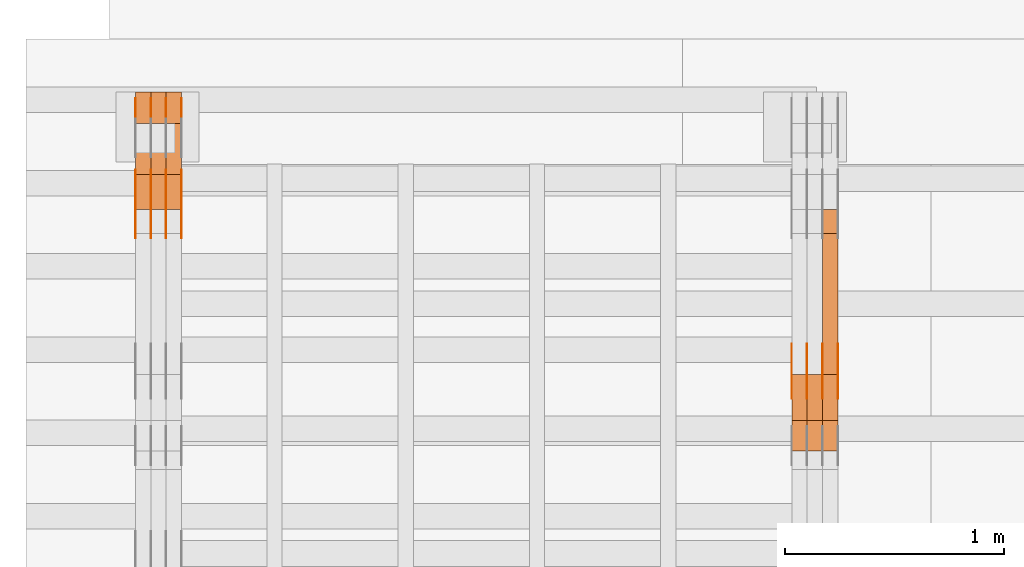
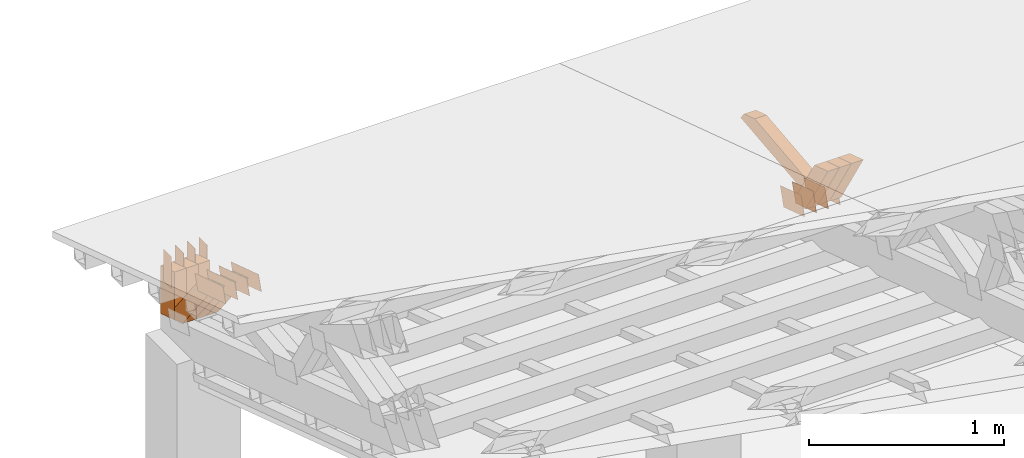
# One storey, part 185 of 385: 28 proxies.
"""IFC2X3 building model written with IfcOpenShell, lengths in millimetres."""

import ifcopenshell
import ifcopenshell.guid

model = None  # the IFC model being written
_history = None  # IfcOwnerHistory: only IFC2X3 demands one
_inside = {}  # id of a spatial element -> (the spatial element, [elements in it])
_under = {}  # id of a project, library or spatial element -> (it, [spatial elements below it])
_declared = {}  # id of a project -> (the project, [libraries it declares])
_typed = {}  # id of a type object -> (the type object, [elements of that type])
_made_of = {}  # id of a material, layer set ... -> (it, [elements and type objects made of it])


def new_model(schema):
    """Start an empty IFC model of exactly this schema.

    Asked for "IFC4X3", IfcOpenShell would pick the latest addendum, in which some entities
    have other attributes; the version numbers below select the first issue.
    IFC2X3 requires an IfcOwnerHistory on every rooted entity: one is made here for all.
    """
    global model, _history
    if schema == "IFC4X3":
        model = ifcopenshell.file(schema_version=(4, 3, 0, 0))
    else:
        model = ifcopenshell.file(schema=schema)
    _inside.clear()
    _under.clear()
    _declared.clear()
    _typed.clear()
    _made_of.clear()
    _history = None
    if model.schema == "IFC2X3":
        org = make("IfcOrganization", Name="unknown")
        user = make(
            "IfcPersonAndOrganization",
            ThePerson=make("IfcPerson", FamilyName="unknown"),
            TheOrganization=org,
        )
        app = make(
            "IfcApplication",
            ApplicationDeveloper=org,
            Version="unknown",
            ApplicationFullName="unknown",
            ApplicationIdentifier="unknown",
        )
        _history = make(
            "IfcOwnerHistory",
            OwningUser=user,
            OwningApplication=app,
            ChangeAction="ADDED",
            CreationDate=0,
        )
    return model


def make(cls, **values):
    """One entity of the class cls with the attributes given. An attribute that is None is left unset."""
    return model.create_entity(
        cls, **{name: value for name, value in values.items() if value is not None}
    )


def entity(cls, *values):
    """Any entity or typed value of the class cls, its attributes in the order of the schema. None: left unset."""
    e = model.create_entity(cls)
    for i, value in enumerate(values):
        if value is not None:
            e[i] = value
    return e


def rooted(cls, **values):
    """An entity with a GlobalId (a new one), such as an element, a storey or a relation."""
    return make(cls, GlobalId=ifcopenshell.guid.new(), OwnerHistory=_history, **values)


def si_unit(unit_type, name, prefix=None):
    """IfcSIUnit, for example si_unit("LENGTHUNIT", "METRE", prefix="MILLI")."""
    return make("IfcSIUnit", UnitType=unit_type, Prefix=prefix, Name=name)


def converted_unit(unit_type, name, factor, base, dimensions=None, offset=None):
    """IfcConversionBasedUnit, such as the inch: factor (a typed value) times the base unit."""
    return make(
        "IfcConversionBasedUnit"
        if offset is None
        else "IfcConversionBasedUnitWithOffset",
        ConversionOffset=offset,
        Dimensions=None
        if dimensions is None
        else entity("IfcDimensionalExponents", *dimensions),
        UnitType=unit_type,
        Name=name,
        ConversionFactor=make(
            "IfcMeasureWithUnit", ValueComponent=factor, UnitComponent=base
        ),
    )


def derived_unit(unit_type, elements):
    """IfcDerivedUnit: a product of units, each with its exponent."""
    return make(
        "IfcDerivedUnit",
        Elements=[
            make("IfcDerivedUnitElement", Unit=unit, Exponent=power)
            for unit, power in elements
        ],
        UnitType=unit_type,
    )


def assignment(units):
    """IfcUnitAssignment: the units of a project."""
    return None if units is None else make("IfcUnitAssignment", Units=units)


def point(xyz):
    """IfcCartesianPoint."""
    return None if xyz is None else make("IfcCartesianPoint", Coordinates=xyz)


def direction(xyz):
    """IfcDirection."""
    return None if xyz is None else make("IfcDirection", DirectionRatios=xyz)


def frame(location, z_axis=None, x_axis=None):
    """IfcAxis2Placement3D, a coordinate frame: its origin and axes. An axis left out is left unset."""
    return make(
        "IfcAxis2Placement3D",
        Location=point(location),
        Axis=direction(z_axis),
        RefDirection=direction(x_axis),
    )


def frame_2d(location, x_axis=None):
    """IfcAxis2Placement2D, a coordinate frame in the plane: its origin and x axis."""
    return make(
        "IfcAxis2Placement2D", Location=point(location), RefDirection=direction(x_axis)
    )


def origin():
    """The frame at (0, 0, 0) with its axes left unset."""
    return frame((0.0, 0.0, 0.0))


def place(relative_to, where):
    """IfcLocalPlacement: puts the frame where relative to a parent placement (None: the world)."""
    return make(
        "IfcLocalPlacement", PlacementRelTo=relative_to, RelativePlacement=where
    )


def context(
    kind, dimensions, precision=None, world=None, true_north=None, identifier=None
):
    """IfcGeometricRepresentationContext, for example the 3D "Model" context."""
    return make(
        "IfcGeometricRepresentationContext",
        ContextIdentifier=identifier,
        ContextType=kind,
        CoordinateSpaceDimension=dimensions,
        Precision=precision,
        WorldCoordinateSystem=world,
        TrueNorth=true_north,
    )


def subcontext(parent, identifier, kind, view, scale=None):
    """IfcGeometricRepresentationSubContext, for example "Body" below "Model"."""
    return make(
        "IfcGeometricRepresentationSubContext",
        ContextIdentifier=identifier,
        ContextType=kind,
        ParentContext=parent,
        TargetScale=scale,
        TargetView=view,
    )


def project(units=None, contexts=None):
    """IfcProject with its units and contexts."""
    return rooted(
        "IfcProject",
        Name="project",
        RepresentationContexts=contexts,
        UnitsInContext=assignment(units),
    )


def spatial(cls, under=None, at=None, **own):
    """A site, building, storey or space (cls), placed at a placement, below another one or the project."""
    s = rooted(cls, ObjectPlacement=at, **own)
    if under is not None:
        _under.setdefault(under.id(), (under, []))[1].append(s)
    return s


def polyline(points):
    """IfcPolyline through the points."""
    return make("IfcPolyline", Points=[point(p) for p in points])


def profile(cls, at=None, kind="AREA", **sizes):
    """A parametric profile (cls). Its sizes go by their IFC names, for example OverallWidth=200.0."""
    return make(cls, ProfileType=kind, Position=at, **sizes)


def rectangle(**sizes):
    """IfcRectangleProfileDef."""
    return profile("IfcRectangleProfileDef", **sizes)


def outline(outer, holes=None, kind="AREA"):
    """IfcArbitraryClosedProfileDef: a profile drawn as a closed curve; with holes, ...WithVoids."""
    if holes is None:
        return make("IfcArbitraryClosedProfileDef", ProfileType=kind, OuterCurve=outer)
    return make(
        "IfcArbitraryProfileDefWithVoids",
        ProfileType=kind,
        OuterCurve=outer,
        InnerCurves=holes,
    )


def extrude(swept, where, along, depth):
    """IfcExtrudedAreaSolid: the profile swept, set in the frame where, extruded along a direction by depth."""
    return make(
        "IfcExtrudedAreaSolid",
        SweptArea=swept,
        Position=where,
        ExtrudedDirection=direction(along),
        Depth=depth,
    )


def shape(context_of_items, identifier, shape_type, items):
    """IfcShapeRepresentation: the items that make up one representation, for example the "Body"."""
    return make(
        "IfcShapeRepresentation",
        ContextOfItems=context_of_items,
        RepresentationIdentifier=identifier,
        RepresentationType=shape_type,
        Items=items,
    )


def source(mapping_origin, context_of_items, identifier, shape_type, items):
    """IfcRepresentationMap: a shape defined once, which mapped items show again and again."""
    return make(
        "IfcRepresentationMap",
        MappingOrigin=mapping_origin,
        MappedRepresentation=shape(context_of_items, identifier, shape_type, items),
    )


def transform(
    local_origin,
    x_axis=None,
    y_axis=None,
    z_axis=None,
    scale=None,
    scale2=None,
    scale3=None,
    uniform=True,
):
    """IfcCartesianTransformationOperator3D, or its non-uniform kind. x_axis, y_axis, z_axis: its Axis1, 2, 3."""
    if uniform:
        return make(
            "IfcCartesianTransformationOperator3D",
            Axis1=direction(x_axis),
            Axis2=direction(y_axis),
            LocalOrigin=point(local_origin),
            Scale=scale,
            Axis3=direction(z_axis),
        )
    return make(
        "IfcCartesianTransformationOperator3DnonUniform",
        Axis1=direction(x_axis),
        Axis2=direction(y_axis),
        LocalOrigin=point(local_origin),
        Scale=scale,
        Axis3=direction(z_axis),
        Scale2=scale2,
        Scale3=scale3,
    )


def mapped(mapping_source, mapping_target):
    """IfcMappedItem: shows the shape of a source again, moved by a transform."""
    return make(
        "IfcMappedItem", MappingSource=mapping_source, MappingTarget=mapping_target
    )


def material(Name=None, Category=None):
    """IfcMaterial."""
    return make("IfcMaterial", Name=Name, Category=Category)


def made_of(thing, what):
    """Note that an element or type object is made of a material, layer set ...; save() writes the relation."""
    if what is not None:
        _made_of.setdefault(what.id(), (what, []))[1].append(thing)
    return thing


def type_object(cls, material=None, **own):
    """A type object (cls), such as IfcWallType, which elements share."""
    return made_of(rooted(cls, **own), material)


def type_shapes(of_type, sources):
    """Give a type object the sources (RepresentationMaps) that its elements show as mapped items."""
    of_type.RepresentationMaps = sources


def element(
    cls,
    number,
    at=None,
    inside=None,
    cuts=None,
    type_object=None,
    material=None,
    context=None,
    identifier="Body",
    shape_type=None,
    held_by="IfcProductDefinitionShape",
    body=None,
    shapes=None,
    **own,
):
    """One element of the class cls, such as IfcWall. Its Tag is "e" and its number.

    at: its placement. inside: the storey or other place that contains it. cuts: it is an
    opening in that element (IfcRelVoidsElement). A single representation is given by context,
    identifier, shape_type and body (its items); several are given by shapes. held_by: the class
    of the entity that holds the representations. save() writes the other relations.
    """
    e = rooted(cls, Tag="e%d" % number, ObjectPlacement=at, **own)
    if body is not None:
        shapes = [shape(context, identifier, shape_type, body)]
    if shapes is not None:
        e.Representation = make(held_by, Representations=shapes)
    if inside is not None:
        _inside.setdefault(inside.id(), (inside, []))[1].append(e)
    if cuts is not None:
        rooted(
            "IfcRelVoidsElement", RelatingBuildingElement=cuts, RelatedOpeningElement=e
        )
    if type_object is not None:
        _typed.setdefault(type_object.id(), (type_object, []))[1].append(e)
    return made_of(e, material)


def aggregate(whole, parts):
    """IfcRelAggregates: a whole, such as a stair, and the parts it consists of."""
    return rooted("IfcRelAggregates", RelatingObject=whole, RelatedObjects=parts)


def save(model, path):
    """Write the relations noted so far, then the file.

    IfcRelAggregates (storeys below a building ...), IfcRelContainedInSpatialStructure (elements
    in a storey), IfcRelDefinesByType, IfcRelAssociatesMaterial and IfcRelDeclares: one each for
    every whole, place, type object, material and project.
    """
    for whole, parts in _under.values():
        aggregate(whole, parts)
    for where, things in _inside.values():
        rooted(
            "IfcRelContainedInSpatialStructure",
            RelatedElements=things,
            RelatingStructure=where,
        )
    for kind, things in _typed.values():
        rooted("IfcRelDefinesByType", RelatedObjects=things, RelatingType=kind)
    for what, things in _made_of.values():
        rooted("IfcRelAssociatesMaterial", RelatedObjects=things, RelatingMaterial=what)
    for by, libraries in _declared.values():
        rooted("IfcRelDeclares", RelatingContext=by, RelatedDefinitions=libraries)
    model.write(path)


model = new_model("IFC2X3")

# Units and contexts
model_context = context("Model", 3, precision=0.01, world=origin(), true_north=direction((6.12303176911189e-17, 1.0)))
body_context = subcontext(model_context, "Body", "Model", "MODEL_VIEW")
ifc_project = project(units=[si_unit("LENGTHUNIT", "METRE", prefix="MILLI"), si_unit("AREAUNIT", "SQUARE_METRE"), si_unit("VOLUMEUNIT", "CUBIC_METRE"), converted_unit("PLANEANGLEUNIT", "DEGREE", entity("IfcRatioMeasure", 0.0174532925199433), si_unit("PLANEANGLEUNIT", "RADIAN"), dimensions=[0, 0, 0, 0, 0, 0, 0]), si_unit("MASSUNIT", "GRAM", prefix="KILO"), derived_unit("MASSDENSITYUNIT", [(si_unit("MASSUNIT", "GRAM", prefix="KILO"), 1), (si_unit("LENGTHUNIT", "METRE"), -3)]), si_unit("TIMEUNIT", "SECOND"), si_unit("FREQUENCYUNIT", "HERTZ"), si_unit("THERMODYNAMICTEMPERATUREUNIT", "DEGREE_CELSIUS"), derived_unit("THERMALTRANSMITTANCEUNIT", [(si_unit("MASSUNIT", "GRAM", prefix="KILO"), 1), (si_unit("THERMODYNAMICTEMPERATUREUNIT", "KELVIN"), -1), (si_unit("TIMEUNIT", "SECOND"), -3)]), derived_unit("VOLUMETRICFLOWRATEUNIT", [(si_unit("LENGTHUNIT", "METRE"), 3), (si_unit("TIMEUNIT", "SECOND"), -1)]), si_unit("ELECTRICCURRENTUNIT", "AMPERE"), si_unit("ELECTRICVOLTAGEUNIT", "VOLT"), si_unit("POWERUNIT", "WATT"), si_unit("FORCEUNIT", "NEWTON", prefix="KILO"), si_unit("ILLUMINANCEUNIT", "LUX"), si_unit("LUMINOUSFLUXUNIT", "LUMEN"), si_unit("LUMINOUSINTENSITYUNIT", "CANDELA"), derived_unit("USERDEFINED", [(si_unit("MASSUNIT", "GRAM", prefix="KILO"), -1), (si_unit("LENGTHUNIT", "METRE"), -2), (si_unit("TIMEUNIT", "SECOND"), 3), (si_unit("LUMINOUSFLUXUNIT", "LUMEN"), 1)]), derived_unit("LINEARVELOCITYUNIT", [(si_unit("LENGTHUNIT", "METRE"), 1), (si_unit("TIMEUNIT", "SECOND"), -1)]), si_unit("PRESSUREUNIT", "PASCAL"), derived_unit("USERDEFINED", [(si_unit("LENGTHUNIT", "METRE"), -2), (si_unit("MASSUNIT", "GRAM", prefix="KILO"), 1), (si_unit("TIMEUNIT", "SECOND"), -2)])], contexts=[model_context])

# Site, building, storey
site_placement = place(None, origin())
site = spatial("IfcSite", under=ifc_project, at=site_placement, CompositionType="ELEMENT")
building_placement = place(site_placement, origin())
building = spatial("IfcBuilding", under=site, at=building_placement, CompositionType="ELEMENT")
storey_placement = place(building_placement, origin())
storey = spatial("IfcBuildingStorey", under=building, at=storey_placement, Name="Default", CompositionType="ELEMENT", Elevation=0.0)

# Proxies
ifc_material_1 = material(Name="IfcSurfaceStyle #56364")
building_element_proxy_type_1 = type_object("IfcBuildingElementProxyType", PredefinedType="NOTDEFINED", material=ifc_material_1)
shared_shape_1 = source(origin(), body_context, "Body", "SweptSolid", [
    extrude(outline(polyline([(-112.50003853564, -60.0000121429077), (112.50002982902, -60.0000121429077), (112.500043250865, 60.0000121429077), (-112.500034544245, 60.0000121429077), (-112.50003853564, -60.0000121429077)])), frame((112.500056021398, 60.0000121429077, 0.0), z_axis=(0.0, 0.0, 1.0), x_axis=(-1.0, 0.0, 0.0)), (0.0, 0.0, 1.0), 1.3),
])
type_shapes(building_element_proxy_type_1, [shared_shape_1])
proxy_1_placement = place(building_placement, frame((3386.29999999999, 25310.2182710494, 430.675738123044), z_axis=(-1.0, 0.0, 0.0), x_axis=(0.0, -0.951056516295124, 0.309016994375039)))
element("IfcBuildingElementProxy", 1, at=proxy_1_placement, inside=storey, type_object=building_element_proxy_type_1, material=ifc_material_1, context=body_context, shape_type="MappedRepresentation", body=[
    mapped(shared_shape_1, transform((0.0, 0.0, 0.0), scale=1.0)),
])
ifc_material_2 = material(Name="IfcSurfaceStyle #56307")
building_element_proxy_type_2 = type_object("IfcBuildingElementProxyType", PredefinedType="NOTDEFINED", material=ifc_material_2)
shared_shape_2 = source(origin(), body_context, "Body", "SweptSolid", [
    extrude(outline(polyline([(-112.50003853564, -60.0000121429077), (112.50002982902, -60.0000121429077), (112.500043250865, 60.0000121429077), (-112.500034544245, 60.0000121429077), (-112.50003853564, -60.0000121429077)])), frame((112.500056021398, 60.0000121429077, 0.0), z_axis=(0.0, 0.0, 1.0), x_axis=(-1.0, 0.0, 0.0)), (0.0, 0.0, 1.0), 1.3),
])
type_shapes(building_element_proxy_type_2, [shared_shape_2])
proxy_2_placement = place(building_placement, frame((3315.0, 25310.2182710494, 430.675738123044), z_axis=(-1.0, 0.0, 0.0), x_axis=(0.0, -0.951056516295124, 0.309016994375039)))
element("IfcBuildingElementProxy", 2, at=proxy_2_placement, inside=storey, type_object=building_element_proxy_type_2, material=ifc_material_2, context=body_context, shape_type="MappedRepresentation", body=[
    mapped(shared_shape_2, transform((0.0, 0.0, 0.0), scale=1.0)),
])
ifc_material_3 = material(Name="IfcSurfaceStyle #56250")
building_element_proxy_type_3 = type_object("IfcBuildingElementProxyType", PredefinedType="NOTDEFINED", material=ifc_material_3)
shared_shape_3 = source(origin(), body_context, "Body", "SweptSolid", [
    extrude(outline(polyline([(-112.50003853564, -60.0000121429077), (112.50002982902, -60.0000121429077), (112.500043250865, 60.0000121429077), (-112.500034544245, 60.0000121429077), (-112.50003853564, -60.0000121429077)])), frame((112.500056021398, 60.0000121429077, 0.0), z_axis=(0.0, 0.0, 1.0), x_axis=(-1.0, 0.0, 0.0)), (0.0, 0.0, 1.0), 1.3),
])
type_shapes(building_element_proxy_type_3, [shared_shape_3])
proxy_3_placement = place(building_placement, frame((3316.29999999999, 25310.2182710494, 430.675738123044), z_axis=(-1.0, 0.0, 0.0), x_axis=(0.0, -0.951056516295124, 0.309016994375039)))
element("IfcBuildingElementProxy", 3, at=proxy_3_placement, inside=storey, type_object=building_element_proxy_type_3, material=ifc_material_3, context=body_context, shape_type="MappedRepresentation", body=[
    mapped(shared_shape_3, transform((0.0, 0.0, 0.0), scale=1.0)),
])
ifc_material_4 = material(Name="IfcSurfaceStyle #56193")
building_element_proxy_type_4 = type_object("IfcBuildingElementProxyType", PredefinedType="NOTDEFINED", material=ifc_material_4)
shared_shape_4 = source(origin(), body_context, "Body", "SweptSolid", [
    extrude(outline(polyline([(-112.50003853564, -60.0000121429077), (112.50002982902, -60.0000121429077), (112.500043250865, 60.0000121429077), (-112.500034544245, 60.0000121429077), (-112.50003853564, -60.0000121429077)])), frame((112.500056021398, 60.0000121429077, 0.0), z_axis=(0.0, 0.0, 1.0), x_axis=(-1.0, 0.0, 0.0)), (0.0, 0.0, 1.0), 1.29999999999998),
])
type_shapes(building_element_proxy_type_4, [shared_shape_4])
proxy_4_placement = place(building_placement, frame((3245.0, 25310.2182710494, 430.675738123044), z_axis=(-1.0, 0.0, 0.0), x_axis=(0.0, -0.951056516295124, 0.309016994375039)))
element("IfcBuildingElementProxy", 4, at=proxy_4_placement, inside=storey, type_object=building_element_proxy_type_4, material=ifc_material_4, context=body_context, shape_type="MappedRepresentation", body=[
    mapped(shared_shape_4, transform((0.0, 0.0, 0.0), scale=1.0)),
])
ifc_material_5 = material(Name="IfcSurfaceStyle #56136")
building_element_proxy_type_5 = type_object("IfcBuildingElementProxyType", PredefinedType="NOTDEFINED", material=ifc_material_5)
shared_shape_5 = source(origin(), body_context, "Body", "SweptSolid", [
    extrude(outline(polyline([(-112.50003853564, -60.0000121429077), (112.50002982902, -60.0000121429077), (112.500043250865, 60.0000121429077), (-112.500034544245, 60.0000121429077), (-112.50003853564, -60.0000121429077)])), frame((112.500056021398, 60.0000121429077, 0.0), z_axis=(0.0, 0.0, 1.0), x_axis=(-1.0, 0.0, 0.0)), (0.0, 0.0, 1.0), 1.29999999999998),
])
type_shapes(building_element_proxy_type_5, [shared_shape_5])
proxy_5_placement = place(building_placement, frame((3246.29999999999, 25310.2182710494, 430.675738123044), z_axis=(-1.0, 0.0, 0.0), x_axis=(0.0, -0.951056516295124, 0.309016994375039)))
element("IfcBuildingElementProxy", 5, at=proxy_5_placement, inside=storey, type_object=building_element_proxy_type_5, material=ifc_material_5, context=body_context, shape_type="MappedRepresentation", body=[
    mapped(shared_shape_5, transform((0.0, 0.0, 0.0), scale=1.0)),
])
ifc_material_6 = material(Name="IfcSurfaceStyle #56079")
building_element_proxy_type_6 = type_object("IfcBuildingElementProxyType", PredefinedType="NOTDEFINED", material=ifc_material_6)
shared_shape_6 = source(origin(), body_context, "Body", "SweptSolid", [
    extrude(outline(polyline([(-112.50003853564, -60.0000121429077), (112.50002982902, -60.0000121429077), (112.500043250865, 60.0000121429077), (-112.500034544245, 60.0000121429077), (-112.50003853564, -60.0000121429077)])), frame((112.500056021398, 60.0000121429077, 0.0), z_axis=(0.0, 0.0, 1.0), x_axis=(-1.0, 0.0, 0.0)), (0.0, 0.0, 1.0), 1.29999999999999),
])
type_shapes(building_element_proxy_type_6, [shared_shape_6])
proxy_6_placement = place(building_placement, frame((3175.0, 25310.2182710494, 430.675738123044), z_axis=(-1.0, 0.0, 0.0), x_axis=(0.0, -0.951056516295124, 0.309016994375039)))
element("IfcBuildingElementProxy", 6, at=proxy_6_placement, inside=storey, type_object=building_element_proxy_type_6, material=ifc_material_6, context=body_context, shape_type="MappedRepresentation", body=[
    mapped(shared_shape_6, transform((0.0, 0.0, 0.0), scale=1.0)),
])
ifc_material_7 = material(Name="IfcSurfaceStyle #44322")
building_element_proxy_type_7 = type_object("IfcBuildingElementProxyType", Name="T1-W31 44320", PredefinedType="NOTDEFINED", material=ifc_material_7)
shared_shape_7 = source(origin(), body_context, "Body", "SweptSolid", [
    extrude(outline(polyline([(-201.245318299844, -47.5000121670808), (204.413774229459, -47.5000121670808), (182.034306640891, 5.35692244583164e-05), (126.70380769348, 47.4999853824686), (-311.906570263987, 47.4999853824686), (-201.245318299844, -47.5000121670808)])), frame((204.413774229459, 47.5002684334588, 0.0), z_axis=(0.0, 0.0, 1.0), x_axis=(-1.0, 0.0, 0.0)), (0.0, 0.0, 1.0), 70.0),
])
type_shapes(building_element_proxy_type_7, [shared_shape_7])
proxy_7_placement = place(building_placement, frame((3385.0, 25127.5652647985, 487.27008059185), z_axis=(-1.0, 0.0, 0.0), x_axis=(0.0, -0.520333970303023, 0.853962855953755)))
element("IfcBuildingElementProxy", 7, at=proxy_7_placement, inside=storey, type_object=building_element_proxy_type_7, material=ifc_material_7, Name="T1-W31", context=body_context, shape_type="MappedRepresentation", body=[
    mapped(shared_shape_7, transform((0.0, 0.0, 0.0), scale=1.0)),
])
ifc_material_8 = material(Name="IfcSurfaceStyle #44256")
building_element_proxy_type_8 = type_object("IfcBuildingElementProxyType", Name="T1-W31 44254", PredefinedType="NOTDEFINED", material=ifc_material_8)
shared_shape_8 = source(origin(), body_context, "Body", "SweptSolid", [
    extrude(outline(polyline([(-201.245318299844, -47.5000121670808), (204.413774229459, -47.5000121670808), (182.034306640891, 5.35692244583164e-05), (126.70380769348, 47.4999853824686), (-311.906570263987, 47.4999853824686), (-201.245318299844, -47.5000121670808)])), frame((204.413774229459, 47.5002684334588, 0.0), z_axis=(0.0, 0.0, 1.0), x_axis=(-1.0, 0.0, 0.0)), (0.0, 0.0, 1.0), 70.0),
])
type_shapes(building_element_proxy_type_8, [shared_shape_8])
proxy_8_placement = place(building_placement, frame((3315.0, 25127.5652647985, 487.27008059185), z_axis=(-1.0, 0.0, 0.0), x_axis=(0.0, -0.520333970303023, 0.853962855953755)))
element("IfcBuildingElementProxy", 8, at=proxy_8_placement, inside=storey, type_object=building_element_proxy_type_8, material=ifc_material_8, Name="T1-W31", context=body_context, shape_type="MappedRepresentation", body=[
    mapped(shared_shape_8, transform((0.0, 0.0, 0.0), scale=1.0)),
])
ifc_material_9 = material(Name="IfcSurfaceStyle #44190")
building_element_proxy_type_9 = type_object("IfcBuildingElementProxyType", Name="T1-W31 44188", PredefinedType="NOTDEFINED", material=ifc_material_9)
shared_shape_9 = source(origin(), body_context, "Body", "SweptSolid", [
    extrude(outline(polyline([(-201.245318299844, -47.5000121670808), (204.413774229459, -47.5000121670808), (182.034306640891, 5.35692244583164e-05), (126.70380769348, 47.4999853824686), (-311.906570263987, 47.4999853824686), (-201.245318299844, -47.5000121670808)])), frame((204.413774229459, 47.5002684334588, 0.0), z_axis=(0.0, 0.0, 1.0), x_axis=(-1.0, 0.0, 0.0)), (0.0, 0.0, 1.0), 70.0),
])
type_shapes(building_element_proxy_type_9, [shared_shape_9])
proxy_9_placement = place(building_placement, frame((3245.0, 25127.5652647985, 487.27008059185), z_axis=(-1.0, 0.0, 0.0), x_axis=(0.0, -0.520333970303023, 0.853962855953755)))
element("IfcBuildingElementProxy", 9, at=proxy_9_placement, inside=storey, type_object=building_element_proxy_type_9, material=ifc_material_9, Name="T1-W31", context=body_context, shape_type="MappedRepresentation", body=[
    mapped(shared_shape_9, transform((0.0, 0.0, 0.0), scale=1.0)),
])
ifc_material_10 = material(Name="IfcSurfaceStyle #43926")
building_element_proxy_type_10 = type_object("IfcBuildingElementProxyType", Name="T1-W4 43924", PredefinedType="NOTDEFINED", material=ifc_material_10)
shared_shape_10 = source(origin(), body_context, "Body", "SweptSolid", [
    extrude(outline(polyline([(-510.077325435179, -47.4999981284922), (188.854793418912, -47.4999981284922), (294.906688207675, 1.67015383116809e-05), (324.289382923648, 47.499989777723), (-297.973539115057, 47.4999897777231), (-510.077325435179, -47.4999981284922)])), frame((324.289382923648, 47.5000278316275, 0.0), z_axis=(0.0, 0.0, 1.0), x_axis=(-1.0, 0.0, 0.0)), (0.0, 0.0, 1.0), 70.0),
])
type_shapes(building_element_proxy_type_10, [shared_shape_10])
proxy_10_placement = place(building_placement, frame((3385.0, 25996.2241251556, 525.69905884318), z_axis=(-1.0, 0.0, 0.0), x_axis=(0.0, -0.994287125203057, -0.106738524701444)))
element("IfcBuildingElementProxy", 10, at=proxy_10_placement, inside=storey, type_object=building_element_proxy_type_10, material=ifc_material_10, Name="T1-W4", context=body_context, shape_type="MappedRepresentation", body=[
    mapped(shared_shape_10, transform((0.0, 0.0, 0.0), scale=1.0)),
])
ifc_material_11 = material(Name="IfcSurfaceStyle #21248")
building_element_proxy_type_11 = type_object("IfcBuildingElementProxyType", PredefinedType="NOTDEFINED", material=ifc_material_11)
shared_shape_11 = source(origin(), body_context, "Body", "SweptSolid", [
    extrude(outline(polyline([(-149.999901061401, -48.0000057587028), (150.000035297123, -48.0000057587028), (149.999910491851, 48.0000057587028), (-150.000044727574, 48.0000057587028), (-149.999901061401, -48.0000057587028)])), frame((150.000035297123, 48.0000632585775, 0.0), z_axis=(0.0, 0.0, 1.0), x_axis=(-1.0, 0.0, 0.0)), (0.0, 0.0, 1.0), 1.29999999999999),
])
type_shapes(building_element_proxy_type_11, [shared_shape_11])
proxy_11_placement = place(building_placement, frame((386.299999999986, 26115.0176968219, 469.58296924555), z_axis=(-1.0, 0.0, 0.0), x_axis=(0.0, -0.951056516295154, 0.309016994374948)))
element("IfcBuildingElementProxy", 11, at=proxy_11_placement, inside=storey, type_object=building_element_proxy_type_11, material=ifc_material_11, context=body_context, shape_type="MappedRepresentation", body=[
    mapped(shared_shape_11, transform((0.0, 0.0, 0.0), scale=1.0)),
])
ifc_material_12 = material(Name="IfcSurfaceStyle #21191")
building_element_proxy_type_12 = type_object("IfcBuildingElementProxyType", PredefinedType="NOTDEFINED", material=ifc_material_12)
shared_shape_12 = source(origin(), body_context, "Body", "SweptSolid", [
    extrude(outline(polyline([(-149.999901061401, -48.0000057587028), (150.000035297123, -48.0000057587028), (149.999910491851, 48.0000057587028), (-150.000044727574, 48.0000057587028), (-149.999901061401, -48.0000057587028)])), frame((150.000035297123, 48.0000632585775, 0.0), z_axis=(0.0, 0.0, 1.0), x_axis=(-1.0, 0.0, 0.0)), (0.0, 0.0, 1.0), 1.29999999999999),
])
type_shapes(building_element_proxy_type_12, [shared_shape_12])
proxy_12_placement = place(building_placement, frame((315.0, 26115.0176968219, 469.58296924555), z_axis=(-1.0, 0.0, 0.0), x_axis=(0.0, -0.951056516295154, 0.309016994374948)))
element("IfcBuildingElementProxy", 12, at=proxy_12_placement, inside=storey, type_object=building_element_proxy_type_12, material=ifc_material_12, context=body_context, shape_type="MappedRepresentation", body=[
    mapped(shared_shape_12, transform((0.0, 0.0, 0.0), scale=1.0)),
])
ifc_material_13 = material(Name="IfcSurfaceStyle #21134")
building_element_proxy_type_13 = type_object("IfcBuildingElementProxyType", PredefinedType="NOTDEFINED", material=ifc_material_13)
shared_shape_13 = source(origin(), body_context, "Body", "SweptSolid", [
    extrude(outline(polyline([(-149.999901061401, -48.0000057587028), (150.000035297123, -48.0000057587028), (149.999910491851, 48.0000057587028), (-150.000044727574, 48.0000057587028), (-149.999901061401, -48.0000057587028)])), frame((150.000035297123, 48.0000632585775, 0.0), z_axis=(0.0, 0.0, 1.0), x_axis=(-1.0, 0.0, 0.0)), (0.0, 0.0, 1.0), 1.29999999999999),
])
type_shapes(building_element_proxy_type_13, [shared_shape_13])
proxy_13_placement = place(building_placement, frame((316.299999999986, 26115.0176968219, 469.58296924555), z_axis=(-1.0, 0.0, 0.0), x_axis=(0.0, -0.951056516295154, 0.309016994374948)))
element("IfcBuildingElementProxy", 13, at=proxy_13_placement, inside=storey, type_object=building_element_proxy_type_13, material=ifc_material_13, context=body_context, shape_type="MappedRepresentation", body=[
    mapped(shared_shape_13, transform((0.0, 0.0, 0.0), scale=1.0)),
])
ifc_material_14 = material(Name="IfcSurfaceStyle #21077")
building_element_proxy_type_14 = type_object("IfcBuildingElementProxyType", PredefinedType="NOTDEFINED", material=ifc_material_14)
shared_shape_14 = source(origin(), body_context, "Body", "SweptSolid", [
    extrude(outline(polyline([(-149.999901061401, -48.0000057587028), (150.000035297123, -48.0000057587028), (149.999910491851, 48.0000057587028), (-150.000044727574, 48.0000057587028), (-149.999901061401, -48.0000057587028)])), frame((150.000035297123, 48.0000632585775, 0.0), z_axis=(0.0, 0.0, 1.0), x_axis=(-1.0, 0.0, 0.0)), (0.0, 0.0, 1.0), 1.29999999999998),
])
type_shapes(building_element_proxy_type_14, [shared_shape_14])
proxy_14_placement = place(building_placement, frame((245.0, 26115.0176968219, 469.58296924555), z_axis=(-1.0, 0.0, 0.0), x_axis=(0.0, -0.951056516295154, 0.309016994374948)))
element("IfcBuildingElementProxy", 14, at=proxy_14_placement, inside=storey, type_object=building_element_proxy_type_14, material=ifc_material_14, context=body_context, shape_type="MappedRepresentation", body=[
    mapped(shared_shape_14, transform((0.0, 0.0, 0.0), scale=1.0)),
])
ifc_material_15 = material(Name="IfcSurfaceStyle #21020")
building_element_proxy_type_15 = type_object("IfcBuildingElementProxyType", PredefinedType="NOTDEFINED", material=ifc_material_15)
shared_shape_15 = source(origin(), body_context, "Body", "SweptSolid", [
    extrude(outline(polyline([(-149.999901061401, -48.0000057587028), (150.000035297123, -48.0000057587028), (149.999910491851, 48.0000057587028), (-150.000044727574, 48.0000057587028), (-149.999901061401, -48.0000057587028)])), frame((150.000035297123, 48.0000632585775, 0.0), z_axis=(0.0, 0.0, 1.0), x_axis=(-1.0, 0.0, 0.0)), (0.0, 0.0, 1.0), 1.29999999999998),
])
type_shapes(building_element_proxy_type_15, [shared_shape_15])
proxy_15_placement = place(building_placement, frame((246.299999999986, 26115.0176968219, 469.58296924555), z_axis=(-1.0, 0.0, 0.0), x_axis=(0.0, -0.951056516295154, 0.309016994374948)))
element("IfcBuildingElementProxy", 15, at=proxy_15_placement, inside=storey, type_object=building_element_proxy_type_15, material=ifc_material_15, context=body_context, shape_type="MappedRepresentation", body=[
    mapped(shared_shape_15, transform((0.0, 0.0, 0.0), scale=1.0)),
])
ifc_material_16 = material(Name="IfcSurfaceStyle #20963")
building_element_proxy_type_16 = type_object("IfcBuildingElementProxyType", PredefinedType="NOTDEFINED", material=ifc_material_16)
shared_shape_16 = source(origin(), body_context, "Body", "SweptSolid", [
    extrude(outline(polyline([(-149.999901061401, -48.0000057587028), (150.000035297123, -48.0000057587028), (149.999910491851, 48.0000057587028), (-150.000044727574, 48.0000057587028), (-149.999901061401, -48.0000057587028)])), frame((150.000035297123, 48.0000632585775, 0.0), z_axis=(0.0, 0.0, 1.0), x_axis=(-1.0, 0.0, 0.0)), (0.0, 0.0, 1.0), 1.29999999999998),
])
type_shapes(building_element_proxy_type_16, [shared_shape_16])
proxy_16_placement = place(building_placement, frame((175.0, 26115.0176968219, 469.58296924555), z_axis=(-1.0, 0.0, 0.0), x_axis=(0.0, -0.951056516295154, 0.309016994374948)))
element("IfcBuildingElementProxy", 16, at=proxy_16_placement, inside=storey, type_object=building_element_proxy_type_16, material=ifc_material_16, context=body_context, shape_type="MappedRepresentation", body=[
    mapped(shared_shape_16, transform((0.0, 0.0, 0.0), scale=1.0)),
])
ifc_material_17 = material(Name="IfcSurfaceStyle #20906")
building_element_proxy_type_17 = type_object("IfcBuildingElementProxyType", PredefinedType="NOTDEFINED", material=ifc_material_17)
shared_shape_17 = source(origin(), body_context, "Body", "SweptSolid", [
    extrude(rectangle(XDim=200.0, YDim=84.0000000000005, at=frame_2d((-2.1316282072803e-14, 1.06581410364015e-14), x_axis=(1.0, 0.0))), frame((100.0, 42.0, 0.0), z_axis=(0.0, 0.0, 1.0), x_axis=(-1.0, 0.0, 0.0)), (0.0, 0.0, 1.0), 1.3),
])
type_shapes(building_element_proxy_type_17, [shared_shape_17])
proxy_17_placement = place(building_placement, frame((386.299999999986, 26469.5000000002, 518.521545410156), z_axis=(-1.0, 0.0, 0.0), x_axis=(0.0, 0.0, -1.0)))
element("IfcBuildingElementProxy", 17, at=proxy_17_placement, inside=storey, type_object=building_element_proxy_type_17, material=ifc_material_17, context=body_context, shape_type="MappedRepresentation", body=[
    mapped(shared_shape_17, transform((0.0, 0.0, 0.0), scale=1.0)),
])
ifc_material_18 = material(Name="IfcSurfaceStyle #20849")
building_element_proxy_type_18 = type_object("IfcBuildingElementProxyType", PredefinedType="NOTDEFINED", material=ifc_material_18)
shared_shape_18 = source(origin(), body_context, "Body", "SweptSolid", [
    extrude(rectangle(XDim=200.0, YDim=84.0000000000005, at=frame_2d((-2.1316282072803e-14, 1.06581410364015e-14), x_axis=(1.0, 0.0))), frame((100.0, 42.0, 0.0), z_axis=(0.0, 0.0, 1.0), x_axis=(-1.0, 0.0, 0.0)), (0.0, 0.0, 1.0), 1.3),
])
type_shapes(building_element_proxy_type_18, [shared_shape_18])
proxy_18_placement = place(building_placement, frame((315.0, 26469.5000000002, 518.521545410156), z_axis=(-1.0, 0.0, 0.0), x_axis=(0.0, 0.0, -1.0)))
element("IfcBuildingElementProxy", 18, at=proxy_18_placement, inside=storey, type_object=building_element_proxy_type_18, material=ifc_material_18, context=body_context, shape_type="MappedRepresentation", body=[
    mapped(shared_shape_18, transform((0.0, 0.0, 0.0), scale=1.0)),
])
ifc_material_19 = material(Name="IfcSurfaceStyle #20792")
building_element_proxy_type_19 = type_object("IfcBuildingElementProxyType", PredefinedType="NOTDEFINED", material=ifc_material_19)
shared_shape_19 = source(origin(), body_context, "Body", "SweptSolid", [
    extrude(rectangle(XDim=200.0, YDim=84.0000000000005, at=frame_2d((-2.1316282072803e-14, 1.06581410364015e-14), x_axis=(1.0, 0.0))), frame((100.0, 42.0, 0.0), z_axis=(0.0, 0.0, 1.0), x_axis=(-1.0, 0.0, 0.0)), (0.0, 0.0, 1.0), 1.3),
])
type_shapes(building_element_proxy_type_19, [shared_shape_19])
proxy_19_placement = place(building_placement, frame((316.299999999986, 26469.5000000002, 518.521545410156), z_axis=(-1.0, 0.0, 0.0), x_axis=(0.0, 0.0, -1.0)))
element("IfcBuildingElementProxy", 19, at=proxy_19_placement, inside=storey, type_object=building_element_proxy_type_19, material=ifc_material_19, context=body_context, shape_type="MappedRepresentation", body=[
    mapped(shared_shape_19, transform((0.0, 0.0, 0.0), scale=1.0)),
])
ifc_material_20 = material(Name="IfcSurfaceStyle #20735")
building_element_proxy_type_20 = type_object("IfcBuildingElementProxyType", PredefinedType="NOTDEFINED", material=ifc_material_20)
shared_shape_20 = source(origin(), body_context, "Body", "SweptSolid", [
    extrude(rectangle(XDim=200.0, YDim=84.0000000000005, at=frame_2d((-2.1316282072803e-14, 1.06581410364015e-14), x_axis=(1.0, 0.0))), frame((100.0, 42.0, 0.0), z_axis=(0.0, 0.0, 1.0), x_axis=(-1.0, 0.0, 0.0)), (0.0, 0.0, 1.0), 1.29999999999998),
])
type_shapes(building_element_proxy_type_20, [shared_shape_20])
proxy_20_placement = place(building_placement, frame((245.0, 26469.5000000002, 518.521545410156), z_axis=(-1.0, 0.0, 0.0), x_axis=(0.0, 0.0, -1.0)))
element("IfcBuildingElementProxy", 20, at=proxy_20_placement, inside=storey, type_object=building_element_proxy_type_20, material=ifc_material_20, context=body_context, shape_type="MappedRepresentation", body=[
    mapped(shared_shape_20, transform((0.0, 0.0, 0.0), scale=1.0)),
])
ifc_material_21 = material(Name="IfcSurfaceStyle #20678")
building_element_proxy_type_21 = type_object("IfcBuildingElementProxyType", PredefinedType="NOTDEFINED", material=ifc_material_21)
shared_shape_21 = source(origin(), body_context, "Body", "SweptSolid", [
    extrude(rectangle(XDim=200.0, YDim=84.0000000000005, at=frame_2d((-2.1316282072803e-14, 1.06581410364015e-14), x_axis=(1.0, 0.0))), frame((100.0, 42.0, 0.0), z_axis=(0.0, 0.0, 1.0), x_axis=(-1.0, 0.0, 0.0)), (0.0, 0.0, 1.0), 1.29999999999998),
])
type_shapes(building_element_proxy_type_21, [shared_shape_21])
proxy_21_placement = place(building_placement, frame((246.299999999986, 26469.5000000002, 518.521545410156), z_axis=(-1.0, 0.0, 0.0), x_axis=(0.0, 0.0, -1.0)))
element("IfcBuildingElementProxy", 21, at=proxy_21_placement, inside=storey, type_object=building_element_proxy_type_21, material=ifc_material_21, context=body_context, shape_type="MappedRepresentation", body=[
    mapped(shared_shape_21, transform((0.0, 0.0, 0.0), scale=1.0)),
])
ifc_material_22 = material(Name="IfcSurfaceStyle #20621")
building_element_proxy_type_22 = type_object("IfcBuildingElementProxyType", PredefinedType="NOTDEFINED", material=ifc_material_22)
shared_shape_22 = source(origin(), body_context, "Body", "SweptSolid", [
    extrude(rectangle(XDim=200.0, YDim=84.0000000000005, at=frame_2d((-2.1316282072803e-14, 1.06581410364015e-14), x_axis=(1.0, 0.0))), frame((100.0, 42.0, 0.0), z_axis=(0.0, 0.0, 1.0), x_axis=(-1.0, 0.0, 0.0)), (0.0, 0.0, 1.0), 1.29999999999999),
])
type_shapes(building_element_proxy_type_22, [shared_shape_22])
proxy_22_placement = place(building_placement, frame((175.0, 26469.5000000002, 518.521545410156), z_axis=(-1.0, 0.0, 0.0), x_axis=(0.0, 0.0, -1.0)))
element("IfcBuildingElementProxy", 22, at=proxy_22_placement, inside=storey, type_object=building_element_proxy_type_22, material=ifc_material_22, context=body_context, shape_type="MappedRepresentation", body=[
    mapped(shared_shape_22, transform((0.0, 0.0, 0.0), scale=1.0)),
])
ifc_material_23 = material(Name="IfcSurfaceStyle #9098")
building_element_proxy_type_23 = type_object("IfcBuildingElementProxyType", Name="T1-W21 9096", PredefinedType="NOTDEFINED", material=ifc_material_23)
shared_shape_23 = source(origin(), body_context, "Body", "SweptSolid", [
    extrude(outline(polyline([(-209.199362597501, -47.5000308982766), (168.813164734153, -47.5000308982766), (229.900717355638, -2.18385470334148e-05), (159.828709317766, 47.5000418175501), (-349.343228810055, 47.5000418175502), (-209.199362597501, -47.5000308982766)])), frame((229.900720156071, 47.5000418175501, 0.0), z_axis=(0.0, 0.0, 1.0), x_axis=(-1.0, 0.0, 0.0)), (0.0, 0.0, 1.0), 70.0),
])
type_shapes(building_element_proxy_type_23, [shared_shape_23])
proxy_23_placement = place(building_placement, frame((385.0, 26317.5019908272, 112.518372832984), z_axis=(-1.0, 0.0, 0.0), x_axis=(0.0, -0.613839629272042, 0.789430750310097)))
element("IfcBuildingElementProxy", 23, at=proxy_23_placement, inside=storey, type_object=building_element_proxy_type_23, material=ifc_material_23, Name="T1-W21", context=body_context, shape_type="MappedRepresentation", body=[
    mapped(shared_shape_23, transform((0.0, 0.0, 0.0), scale=1.0)),
])
ifc_material_24 = material(Name="IfcSurfaceStyle #9032")
building_element_proxy_type_24 = type_object("IfcBuildingElementProxyType", Name="T1-W21 9030", PredefinedType="NOTDEFINED", material=ifc_material_24)
shared_shape_24 = source(origin(), body_context, "Body", "SweptSolid", [
    extrude(outline(polyline([(-209.199362597501, -47.5000308982766), (168.813164734153, -47.5000308982766), (229.900717355638, -2.18385470334148e-05), (159.828709317766, 47.5000418175501), (-349.343228810055, 47.5000418175502), (-209.199362597501, -47.5000308982766)])), frame((229.900720156071, 47.5000418175501, 0.0), z_axis=(0.0, 0.0, 1.0), x_axis=(-1.0, 0.0, 0.0)), (0.0, 0.0, 1.0), 70.0),
])
type_shapes(building_element_proxy_type_24, [shared_shape_24])
proxy_24_placement = place(building_placement, frame((315.0, 26317.5019908272, 112.518372832984), z_axis=(-1.0, 0.0, 0.0), x_axis=(0.0, -0.613839629272042, 0.789430750310097)))
element("IfcBuildingElementProxy", 24, at=proxy_24_placement, inside=storey, type_object=building_element_proxy_type_24, material=ifc_material_24, Name="T1-W21", context=body_context, shape_type="MappedRepresentation", body=[
    mapped(shared_shape_24, transform((0.0, 0.0, 0.0), scale=1.0)),
])
ifc_material_25 = material(Name="IfcSurfaceStyle #8966")
building_element_proxy_type_25 = type_object("IfcBuildingElementProxyType", Name="T1-W21 8964", PredefinedType="NOTDEFINED", material=ifc_material_25)
shared_shape_25 = source(origin(), body_context, "Body", "SweptSolid", [
    extrude(outline(polyline([(-209.199362597501, -47.5000308982766), (168.813164734153, -47.5000308982766), (229.900717355638, -2.18385470334148e-05), (159.828709317766, 47.5000418175501), (-349.343228810055, 47.5000418175502), (-209.199362597501, -47.5000308982766)])), frame((229.900720156071, 47.5000418175501, 0.0), z_axis=(0.0, 0.0, 1.0), x_axis=(-1.0, 0.0, 0.0)), (0.0, 0.0, 1.0), 70.0),
])
type_shapes(building_element_proxy_type_25, [shared_shape_25])
proxy_25_placement = place(building_placement, frame((245.0, 26317.5019908272, 112.518372832984), z_axis=(-1.0, 0.0, 0.0), x_axis=(0.0, -0.613839629272042, 0.789430750310097)))
element("IfcBuildingElementProxy", 25, at=proxy_25_placement, inside=storey, type_object=building_element_proxy_type_25, material=ifc_material_25, Name="T1-W21", context=body_context, shape_type="MappedRepresentation", body=[
    mapped(shared_shape_25, transform((0.0, 0.0, 0.0), scale=1.0)),
])
ifc_material_26 = material(Name="IfcSurfaceStyle #8531")
building_element_proxy_type_26 = type_object("IfcBuildingElementProxyType", Name="T1-E2 8529", PredefinedType="NOTDEFINED", material=ifc_material_26)
shared_shape_26 = source(origin(), body_context, "Body", "SweptSolid", [
    extrude(outline(polyline([(-126.644535064697, -72.4999999999998), (173.757884979248, -72.4999999999998), (126.644542694092, 72.4999999999998), (-173.757892608642, 72.4999999999998), (-126.644535064697, -72.4999999999998)])), frame((173.757890653796, 72.5000000000002, 0.0), z_axis=(0.0, 0.0, 1.0), x_axis=(-1.0, 0.0, 0.0)), (0.0, 0.0, 1.0), 70.0),
])
type_shapes(building_element_proxy_type_26, [shared_shape_26])
proxy_26_placement = place(building_placement, frame((385.0, 26500.0, 442.078222227283), z_axis=(-1.0, 0.0, 0.0), x_axis=(0.0, 0.0, -1.0)))
element("IfcBuildingElementProxy", 26, at=proxy_26_placement, inside=storey, type_object=building_element_proxy_type_26, material=ifc_material_26, Name="T1-E2", context=body_context, shape_type="MappedRepresentation", body=[
    mapped(shared_shape_26, transform((0.0, 0.0, 0.0), scale=1.0)),
])
ifc_material_27 = material(Name="IfcSurfaceStyle #8474")
building_element_proxy_type_27 = type_object("IfcBuildingElementProxyType", Name="T1-E2 8472", PredefinedType="NOTDEFINED", material=ifc_material_27)
shared_shape_27 = source(origin(), body_context, "Body", "SweptSolid", [
    extrude(outline(polyline([(-126.644535064697, -72.4999999999998), (173.757884979248, -72.4999999999998), (126.644542694092, 72.4999999999998), (-173.757892608642, 72.4999999999998), (-126.644535064697, -72.4999999999998)])), frame((173.757890653796, 72.5000000000002, 0.0), z_axis=(0.0, 0.0, 1.0), x_axis=(-1.0, 0.0, 0.0)), (0.0, 0.0, 1.0), 70.0),
])
type_shapes(building_element_proxy_type_27, [shared_shape_27])
proxy_27_placement = place(building_placement, frame((315.0, 26500.0, 442.078222227283), z_axis=(-1.0, 0.0, 0.0), x_axis=(0.0, 0.0, -1.0)))
element("IfcBuildingElementProxy", 27, at=proxy_27_placement, inside=storey, type_object=building_element_proxy_type_27, material=ifc_material_27, Name="T1-E2", context=body_context, shape_type="MappedRepresentation", body=[
    mapped(shared_shape_27, transform((0.0, 0.0, 0.0), scale=1.0)),
])
ifc_material_28 = material(Name="IfcSurfaceStyle #8417")
building_element_proxy_type_28 = type_object("IfcBuildingElementProxyType", Name="T1-E2 8415", PredefinedType="NOTDEFINED", material=ifc_material_28)
shared_shape_28 = source(origin(), body_context, "Body", "SweptSolid", [
    extrude(outline(polyline([(-126.644535064697, -72.4999999999998), (173.757884979248, -72.4999999999998), (126.644542694092, 72.4999999999998), (-173.757892608642, 72.4999999999998), (-126.644535064697, -72.4999999999998)])), frame((173.757890653796, 72.5000000000002, 0.0), z_axis=(0.0, 0.0, 1.0), x_axis=(-1.0, 0.0, 0.0)), (0.0, 0.0, 1.0), 70.0),
])
type_shapes(building_element_proxy_type_28, [shared_shape_28])
proxy_28_placement = place(building_placement, frame((245.0, 26500.0, 442.078222227283), z_axis=(-1.0, 0.0, 0.0), x_axis=(0.0, 0.0, -1.0)))
element("IfcBuildingElementProxy", 28, at=proxy_28_placement, inside=storey, type_object=building_element_proxy_type_28, material=ifc_material_28, Name="T1-E2", context=body_context, shape_type="MappedRepresentation", body=[
    mapped(shared_shape_28, transform((0.0, 0.0, 0.0), scale=1.0)),
])

save(model, "model.ifc")
